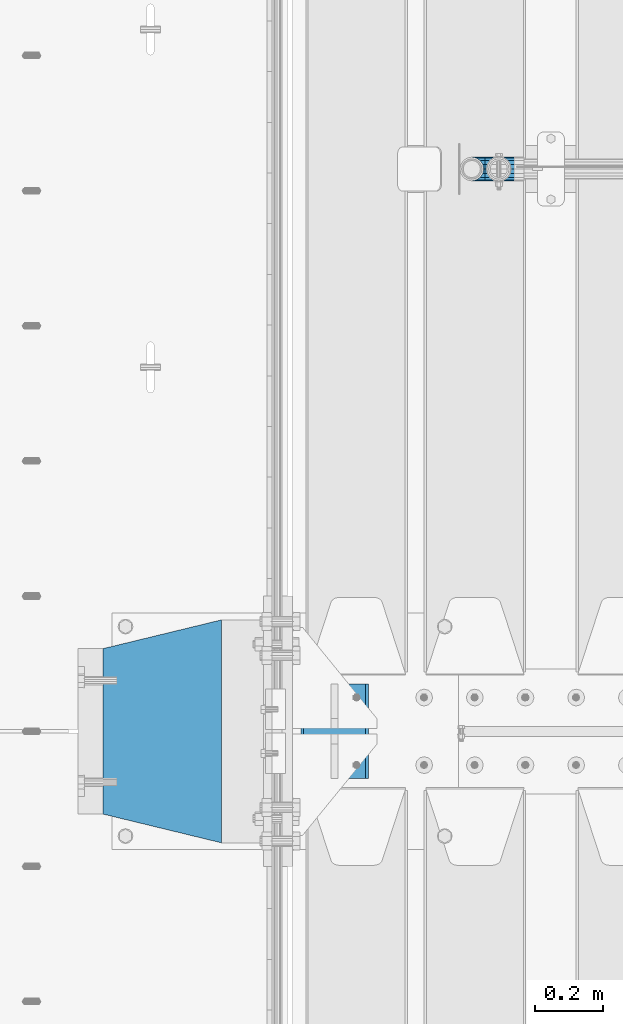
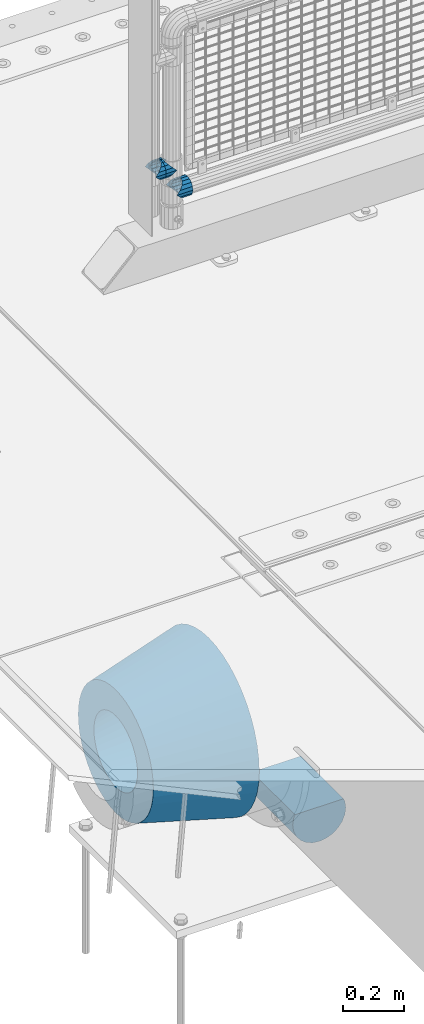
# One storey, part 144 of 240: 5 beams.
"""IFC2X3 building model written with IfcOpenShell, lengths in millimetres."""

from ifc_helpers import new_model, si_unit, frame, origin_with_axes, place, context, subcontext, project, spatial, faceted_brep, material, type_object, element, save


model = new_model("IFC2X3")

# Units and contexts
model_context = context("Model", 3, precision=1e-05, world=origin_with_axes())
body_context = subcontext(model_context, "Body", "Model", "MODEL_VIEW")
ifc_project = project(units=[si_unit("LENGTHUNIT", "METRE", prefix="MILLI"), si_unit("AREAUNIT", "SQUARE_METRE"), si_unit("VOLUMEUNIT", "CUBIC_METRE"), si_unit("MASSUNIT", "GRAM", prefix="KILO"), si_unit("TIMEUNIT", "SECOND"), si_unit("PLANEANGLEUNIT", "RADIAN"), si_unit("SOLIDANGLEUNIT", "STERADIAN"), si_unit("THERMODYNAMICTEMPERATUREUNIT", "DEGREE_CELSIUS"), si_unit("LUMINOUSINTENSITYUNIT", "LUMEN")], contexts=[model_context])

# Site, building, storey
site_placement = place(None, origin_with_axes())
site = spatial("IfcSite", under=ifc_project, at=site_placement, CompositionType="ELEMENT")
building_placement = place(site_placement, origin_with_axes())
building = spatial("IfcBuilding", under=site, at=building_placement, Name="Standard", CompositionType="ELEMENT")
storey_placement = place(building_placement, origin_with_axes())
storey = spatial("IfcBuildingStorey", under=building, at=storey_placement, Name="Undefined", CompositionType="ELEMENT", Elevation=0.0)

# Beams
ifc_material_1 = material(Name="STEEL/S355N")
beam_type_1 = type_object("IfcBeamType", Name="D200", PredefinedType="NOTDEFINED")
beam_1_placement = place(storey_placement, frame((42585.0, 32860.0, -928.0), z_axis=(0.0, 0.0, 1.0), x_axis=(0.0, 1.0, 0.0)))
element("IfcBeam", 1, at=beam_1_placement, inside=storey, type_object=beam_type_1, material=ifc_material_1, ObjectType="D200", context=body_context, shape_type="Brep", body=[
    faceted_brep([(0.0, 100.0, 0.0), (0.0, 96.5925826289094, 25.8819045102521), (280.0, 96.5925826289094, 25.8819045102521), (280.0, 100.0, 0.0), (0.0, 96.5925826289094, -25.8819045102521), (280.0, 96.5925826289094, -25.8819045102521), (0.0, 86.6025403784442, -50.0), (280.0, 86.6025403784442, -50.0), (0.0, 70.7106781186521, -70.7106781186548), (280.0, 70.7106781186521, -70.7106781186548), (0.0, 50.0, -86.6025403784438), (280.0, 50.0, -86.6025403784438), (0.0, 25.88190451025, -96.5925826289067), (280.0, 25.88190451025, -96.5925826289067), (0.0, 0.0, -100.0), (280.0, 0.0, -100.0), (0.0, -25.88190451025, -96.5925826289069), (280.0, -25.88190451025, -96.5925826289069), (0.0, -50.0, -86.6025403784439), (280.0, -50.0, -86.6025403784439), (0.0, -70.7106781186521, -70.7106781186548), (280.0, -70.7106781186521, -70.7106781186548), (0.0, -86.6025403784442, -50.0), (280.0, -86.6025403784442, -50.0), (0.0, -96.5925826289094, -25.8819045102522), (280.0, -96.5925826289094, -25.8819045102522), (0.0, -100.0, 0.0), (280.0, -100.0, 0.0), (0.0, -96.5925826289094, 25.8819045102521), (280.0, -96.5925826289094, 25.8819045102521), (280.0, -91.5731031269243, 38.0), (0.0, -91.5731031269243, 38.0), (0.0, 91.5731031269243, 38.0), (280.0, 91.5731031269243, 38.0)], [[[0, 1, 2, 3]], [[4, 0, 3, 5]], [[6, 4, 5, 7]], [[8, 6, 7, 9]], [[10, 8, 9, 11]], [[12, 10, 11, 13]], [[14, 12, 13, 15]], [[16, 14, 15, 17]], [[18, 16, 17, 19]], [[20, 18, 19, 21]], [[22, 20, 21, 23]], [[24, 22, 23, 25]], [[26, 24, 25, 27]], [[28, 26, 27, 29]], [[28, 29, 30, 31]], [[1, 0, 4, 6, 8, 10, 12, 14, 16, 18, 20, 22, 24, 26, 28, 31, 32]], [[2, 1, 32, 33]], [[29, 27, 25, 23, 21, 19, 17, 15, 13, 11, 9, 7, 5, 3, 2, 33, 30]], [[32, 31, 30, 33]]]),
])
ifc_material_2 = material(Name="Misc_Undefined")
beam_type_2 = type_object("IfcBeamType", PredefinedType="NOTDEFINED")
beam_2_placement = place(storey_placement, frame((43071.0, 34664.5, 298.67), z_axis=(0.0, 1.0, 0.0), x_axis=(1.0, 0.0, 0.0)))
element("IfcBeam", 2, at=beam_2_placement, inside=storey, type_object=beam_type_2, material=ifc_material_2, context=body_context, shape_type="Brep", body=[
    faceted_brep([(0.0, 0.0, 35.1500000000015), (13.4513226476338, 13.4513226476329, 32.4743655677739), (13.4513226476338, -13.4513226476329, 32.4743655677739), (24.8548033587067, -16.3810424079947, -24.8548033587067), (24.8548033587067, -24.8548033587072, -24.8548033587067), (32.4743655677739, -32.4743655677717, -13.4513226476338), (32.4743655677739, -26.8123795176712, -13.4513226476338), (27.1226768591223, -21.4606908090117, -21.4606908090136), (0.0, 0.0, -35.1500000000015), (13.4513226476338, -13.4513226476329, -32.4743655677739), (13.4513226476338, 13.4513226476329, -32.4743655677739), (20.0882031229994, -11.6144421722805, -28.0397438117143), (16.6306603983758, 0.0, -30.3499999999985), (20.0882031229994, 11.6144421722805, -28.0397438117143), (24.8548033587067, 16.3810424080013, -24.8548033587067), (24.8548033587067, 24.8548033587072, -24.8548033587067), (27.1226768591223, 21.4606908090117, -21.4606908090136), (32.4743655677739, 26.8123795176712, -13.4513226476338), (32.4743655677739, 32.4743655677717, -13.4513226476338), (32.8397438117172, 28.0397438117175, -11.6144421722784), (35.1500000000015, 30.35, 0.0), (35.1500000000015, 35.15, 0.0), (32.8397438117099, 28.0397438117175, 11.6144421722784), (32.4743655677739, 26.8123795176755, 13.4513226476338), (32.4743655677739, 32.4743655677717, 13.4513226476338), (27.1226768591005, 21.4606908090117, 21.4606908090136), (24.8548033587067, 16.3810424080013, 24.8548033587067), (24.8548033587067, 24.8548033587072, 24.8548033587067), (20.0882031229849, 11.6144421722805, 28.0397438117143), (16.6306603983685, 0.0, 30.3499999999985), (20.0882031229849, -11.6144421722805, 28.0397438117143), (24.8548033587067, -16.3810424080078, 24.8548033587067), (24.8548033587067, -24.8548033587072, 24.8548033587067), (27.1226768591005, -21.4606908090117, 21.4606908090136), (32.4743655677739, -26.8123795176712, 13.4513226476338), (32.4743655677739, -32.4743655677717, 13.4513226476338), (32.8397438117099, -28.0397438117175, 11.6144421722784), (35.1500000000015, -30.35, 0.0), (35.1500000000015, -35.15, 0.0), (32.8397438117172, -28.0397438117175, -11.6144421722784), (60.1500000000015, -24.8548033587072, -24.8548033587067), (60.1500000000015, -32.4743655677717, -13.4513226476338), (60.1500000000015, -13.4513226476329, -32.4743655677739), (60.1500000000015, 0.0, -35.1500000000015), (60.1500000000015, 13.4513226476329, -32.4743655677739), (60.1500000000015, 24.8548033587072, -24.8548033587067), (60.1500000000015, 32.4743655677717, -13.4513226476338), (60.1500000000015, 35.15, 0.0), (60.1500000000015, 32.4743655677717, 13.4513226476338), (60.1500000000015, 24.8548033587072, 24.8548033587067), (60.1500000000015, 13.4513226476329, 32.4743655677739), (60.1500000000015, 0.0, 35.1500000000015), (60.1500000000015, -13.4513226476329, 32.4743655677739), (60.1500000000015, -24.8548033587072, 24.8548033587067), (60.1500000000015, -32.4743655677717, 13.4513226476338), (60.1500000000015, -35.15, 0.0), (60.1500000000015, -21.4606908090117, 21.4606908090136), (60.1500000000015, -11.6144421722805, 28.0397438117143), (60.1500000000015, 0.0, 30.3499999999985), (60.1500000000015, 11.6144421722805, 28.0397438117143), (60.1500000000015, 21.4606908090117, 21.4606908090136), (60.1500000000015, 28.0397438117175, 11.6144421722784), (60.1500000000015, 30.35, 0.0), (60.1500000000015, 28.0397438117175, -11.6144421722784), (60.1500000000015, 21.4606908090117, -21.4606908090136), (60.1500000000015, 11.6144421722805, -28.0397438117143), (60.1500000000015, 0.0, -30.3499999999985), (60.1500000000015, -11.6144421722805, -28.0397438117143), (60.1500000000015, -21.4606908090117, -21.4606908090136), (60.1500000000015, -28.0397438117175, -11.6144421722784), (60.1500000000015, -30.35, 0.0), (60.1500000000015, -28.0397438117175, 11.6144421722784)], [[[0, 1, 2]], [[3, 4, 5, 6, 7]], [[8, 9, 10]], [[10, 9, 4, 3, 11, 12, 13, 14, 15]], [[15, 14, 16, 17, 18]], [[18, 17, 19, 20, 21]], [[21, 20, 22, 23, 24]], [[24, 23, 25, 26, 27]], [[27, 26, 28, 29, 30, 31, 32, 2, 1]], [[33, 34, 35, 32, 31]], [[36, 37, 38, 35, 34]], [[6, 5, 38, 37, 39]], [[40, 41, 5, 4]], [[42, 40, 4, 9]], [[43, 42, 9, 8]], [[44, 43, 8, 10]], [[45, 44, 10, 15]], [[46, 45, 15, 18]], [[47, 46, 18, 21]], [[48, 47, 21, 24]], [[49, 48, 24, 27]], [[50, 49, 27, 1]], [[51, 50, 1, 0]], [[52, 51, 0, 2]], [[53, 52, 2, 32]], [[54, 53, 32, 35]], [[55, 54, 35, 38]], [[41, 55, 38, 5]], [[40, 42, 43, 44, 45, 46, 47, 48, 49, 50, 51, 52, 53, 54, 55, 41], [56, 57, 58, 59, 60, 61, 62, 63, 64, 65, 66, 67, 68, 69, 70, 71]], [[71, 70, 37, 36]], [[56, 71, 36, 34, 33]], [[57, 56, 33, 31, 30]], [[58, 57, 30, 29]], [[59, 58, 29, 28]], [[25, 60, 59, 28, 26]], [[22, 61, 60, 25, 23]], [[62, 61, 22, 20]], [[63, 62, 20, 19]], [[64, 63, 19, 17, 16]], [[65, 64, 16, 14, 13]], [[66, 65, 13, 12]], [[67, 66, 12, 11]], [[7, 68, 67, 11, 3]], [[39, 69, 68, 7, 6]], [[70, 69, 39, 37]]]),
])
beam_3_placement = place(storey_placement, frame((42991.0, 34664.5, 398.670000000001), z_axis=(0.0, -1.0, 0.0), x_axis=(1.0, 0.0, 0.0)))
element("IfcBeam", 3, at=beam_3_placement, inside=storey, type_object=beam_type_2, material=ifc_material_2, context=body_context, shape_type="Brep", body=[
    faceted_brep([(0.0, 0.0, -35.1500000000015), (13.4513226476338, -13.4513226476329, -32.4743655677739), (13.4513226476338, 13.4513226476329, -32.4743655677739), (32.4743655677739, 32.4743655677717, 13.4513226476338), (32.4743655677739, 26.8123795176755, 13.4513226476338), (27.1226768591005, 21.4606908090117, 21.4606908090136), (24.8548033587067, 16.3810424080013, 24.8548033587067), (24.8548033587067, 24.8548033587072, 24.8548033587067), (0.0, 0.0, 35.1500000000015), (13.4513226476338, 13.4513226476329, 32.4743655677739), (13.4513226476338, -13.4513226476329, 32.4743655677739), (20.0882031229849, 11.6144421722805, 28.0397438117143), (16.6306603983685, 0.0, 30.3499999999985), (20.0882031229849, -11.6144421722805, 28.0397438117143), (24.8548033587067, -16.3810424080078, 24.8548033587067), (24.8548033587067, -24.8548033587072, 24.8548033587067), (27.1226768591005, -21.4606908090117, 21.4606908090136), (32.4743655677739, -26.8123795176712, 13.4513226476338), (32.4743655677739, -32.4743655677717, 13.4513226476338), (32.8397438117099, -28.0397438117175, 11.6144421722784), (35.1500000000015, -30.35, 0.0), (35.1500000000015, -35.15, 0.0), (32.4743655677739, -26.8123795176712, -13.4513226476338), (32.4743655677739, -32.4743655677717, -13.4513226476338), (32.8397438117172, -28.0397438117175, -11.6144421722784), (24.8548033587067, -16.3810424079947, -24.8548033587067), (24.8548033587067, -24.8548033587072, -24.8548033587067), (27.1226768591223, -21.4606908090117, -21.4606908090136), (20.0882031229994, -11.6144421722805, -28.0397438117143), (16.6306603983758, 0.0, -30.3499999999985), (20.0882031229994, 11.6144421722805, -28.0397438117143), (24.8548033587067, 16.3810424080013, -24.8548033587067), (24.8548033587067, 24.8548033587072, -24.8548033587067), (27.1226768591223, 21.4606908090117, -21.4606908090136), (32.4743655677739, 26.8123795176712, -13.4513226476338), (32.4743655677739, 32.4743655677717, -13.4513226476338), (32.8397438117172, 28.0397438117175, -11.6144421722784), (35.1500000000015, 30.35, 0.0), (35.1500000000015, 35.15, 0.0), (32.8397438117099, 28.0397438117175, 11.6144421722784), (40.1500000000015, -35.15, 0.0), (40.1500000000015, -32.4743655677717, 13.4513226476338), (40.1500000000015, -24.8548033587072, 24.8548033587067), (40.1500000000015, -13.4513226476329, 32.4743655677739), (40.1500000000015, 0.0, 35.1500000000015), (40.1500000000015, 13.4513226476329, 32.4743655677739), (40.1500000000015, 24.8548033587072, 24.8548033587067), (40.1500000000015, 32.4743655677717, 13.4513226476338), (40.1500000000015, 35.15, 0.0), (40.1500000000015, -24.8548033587072, -24.8548033587067), (40.1500000000015, -32.4743655677717, -13.4513226476338), (40.1500000000015, -13.4513226476329, -32.4743655677739), (40.1500000000015, 0.0, -35.1500000000015), (40.1500000000015, 13.4513226476329, -32.4743655677739), (40.1500000000015, 24.8548033587072, -24.8548033587067), (40.1500000000015, 32.4743655677717, -13.4513226476338), (40.1500000000015, -21.4606908090117, 21.4606908090136), (40.1500000000015, -11.6144421722805, 28.0397438117143), (40.1500000000015, 0.0, 30.3499999999985), (40.1500000000015, 11.6144421722805, 28.0397438117143), (40.1500000000015, 21.4606908090117, 21.4606908090136), (40.1500000000015, 28.0397438117175, 11.6144421722784), (40.1500000000015, 30.35, 0.0), (40.1500000000015, 28.0397438117175, -11.6144421722784), (40.1500000000015, 21.4606908090117, -21.4606908090136), (40.1500000000015, 11.6144421722805, -28.0397438117143), (40.1500000000015, 0.0, -30.3499999999985), (40.1500000000015, -11.6144421722805, -28.0397438117143), (40.1500000000015, -21.4606908090117, -21.4606908090136), (40.1500000000015, -28.0397438117175, -11.6144421722784), (40.1500000000015, -30.35, 0.0), (40.1500000000015, -28.0397438117175, 11.6144421722784)], [[[0, 1, 2]], [[3, 4, 5, 6, 7]], [[8, 9, 10]], [[7, 6, 11, 12, 13, 14, 15, 10, 9]], [[16, 17, 18, 15, 14]], [[19, 20, 21, 18, 17]], [[22, 23, 21, 20, 24]], [[25, 26, 23, 22, 27]], [[2, 1, 26, 25, 28, 29, 30, 31, 32]], [[32, 31, 33, 34, 35]], [[35, 34, 36, 37, 38]], [[38, 37, 39, 4, 3]], [[40, 41, 18, 21]], [[41, 42, 15, 18]], [[42, 43, 10, 15]], [[43, 44, 8, 10]], [[44, 45, 9, 8]], [[45, 46, 7, 9]], [[46, 47, 3, 7]], [[47, 48, 38, 3]], [[49, 50, 23, 26]], [[51, 49, 26, 1]], [[52, 51, 1, 0]], [[53, 52, 0, 2]], [[54, 53, 2, 32]], [[55, 54, 32, 35]], [[48, 55, 35, 38]], [[50, 40, 21, 23]], [[49, 51, 52, 53, 54, 55, 48, 47, 46, 45, 44, 43, 42, 41, 40, 50], [56, 57, 58, 59, 60, 61, 62, 63, 64, 65, 66, 67, 68, 69, 70, 71]], [[63, 62, 37, 36]], [[33, 64, 63, 36, 34]], [[30, 65, 64, 33, 31]], [[66, 65, 30, 29]], [[67, 66, 29, 28]], [[68, 67, 28, 25, 27]], [[69, 68, 27, 22, 24]], [[70, 69, 24, 20]], [[71, 70, 20, 19]], [[16, 56, 71, 19, 17]], [[13, 57, 56, 16, 14]], [[58, 57, 13, 12]], [[59, 58, 12, 11]], [[60, 59, 11, 6, 5]], [[61, 60, 5, 4, 39]], [[62, 61, 39, 37]]]),
])
beam_4_placement = place(storey_placement, frame((43071.0, 34664.5, 398.670000000001), z_axis=(0.0, 1.0, 0.0), x_axis=(-1.0, 0.0, 0.0)))
element("IfcBeam", 4, at=beam_4_placement, inside=storey, type_object=beam_type_2, material=ifc_material_2, context=body_context, shape_type="Brep", body=[
    faceted_brep([(0.0, 0.0, -35.1500000000015), (13.4513226476338, -13.4513226476329, -32.4743655677739), (13.4513226476338, 13.4513226476329, -32.4743655677739), (27.1226768591005, -21.4606908090117, 21.4606908090136), (32.4743655677739, -26.8123795176712, 13.4513226476338), (32.4743655677739, -32.4743655677717, 13.4513226476338), (24.8548033587067, -24.8548033587072, 24.8548033587067), (24.8548033587067, -16.3810424080078, 24.8548033587067), (32.8397438117099, -28.0397438117175, 11.6144421722784), (35.1500000000015, -30.35, 0.0), (35.1500000000015, -35.15, 0.0), (32.4743655677739, -26.8123795176712, -13.4513226476338), (32.4743655677739, -32.4743655677717, -13.4513226476338), (32.8397438117172, -28.0397438117175, -11.6144421722784), (24.8548033587067, -16.3810424079947, -24.8548033587067), (24.8548033587067, -24.8548033587072, -24.8548033587067), (27.1226768591223, -21.4606908090117, -21.4606908090136), (20.0882031229994, -11.6144421722805, -28.0397438117143), (16.6306603983758, 0.0, -30.3499999999985), (20.0882031229994, 11.6144421722805, -28.0397438117143), (24.8548033587067, 16.3810424080013, -24.8548033587067), (24.8548033587067, 24.8548033587072, -24.8548033587067), (27.1226768591223, 21.4606908090117, -21.4606908090136), (32.4743655677739, 26.8123795176712, -13.4513226476338), (32.4743655677739, 32.4743655677717, -13.4513226476338), (32.8397438117172, 28.0397438117175, -11.6144421722784), (35.1500000000015, 30.35, 0.0), (35.1500000000015, 35.15, 0.0), (32.8397438117099, 28.0397438117175, 11.6144421722784), (32.4743655677739, 26.8123795176755, 13.4513226476338), (32.4743655677739, 32.4743655677717, 13.4513226476338), (27.1226768591005, 21.4606908090117, 21.4606908090136), (24.8548033587067, 16.3810424080013, 24.8548033587067), (24.8548033587067, 24.8548033587072, 24.8548033587067), (0.0, 0.0, 35.1500000000015), (13.4513226476338, 13.4513226476329, 32.4743655677739), (13.4513226476338, -13.4513226476329, 32.4743655677739), (20.0882031229849, 11.6144421722805, 28.0397438117143), (16.6306603983685, 0.0, 30.3499999999985), (20.0882031229849, -11.6144421722805, 28.0397438117143), (40.1500000000015, -35.15, 0.0), (40.1500000000015, -32.4743655677717, 13.4513226476338), (40.1500000000015, -24.8548033587072, 24.8548033587067), (40.1500000000015, -13.4513226476329, 32.4743655677739), (40.1500000000015, 0.0, 35.1500000000015), (40.1500000000015, -24.8548033587072, -24.8548033587067), (40.1500000000015, -32.4743655677717, -13.4513226476338), (40.1500000000015, -13.4513226476329, -32.4743655677739), (40.1500000000015, 0.0, -35.1500000000015), (40.1500000000015, 13.4513226476329, -32.4743655677739), (40.1500000000015, 24.8548033587072, -24.8548033587067), (40.1500000000015, 32.4743655677717, -13.4513226476338), (40.1500000000015, 35.15, 0.0), (40.1500000000015, 32.4743655677717, 13.4513226476338), (40.1500000000015, 24.8548033587072, 24.8548033587067), (40.1500000000015, 13.4513226476329, 32.4743655677739), (40.1500000000015, -21.4606908090117, 21.4606908090136), (40.1500000000015, -11.6144421722805, 28.0397438117143), (40.1500000000015, 0.0, 30.3499999999985), (40.1500000000015, 11.6144421722805, 28.0397438117143), (40.1500000000015, 21.4606908090117, 21.4606908090136), (40.1500000000015, 28.0397438117175, 11.6144421722784), (40.1500000000015, 30.35, 0.0), (40.1500000000015, 28.0397438117175, -11.6144421722784), (40.1500000000015, 21.4606908090117, -21.4606908090136), (40.1500000000015, 11.6144421722805, -28.0397438117143), (40.1500000000015, 0.0, -30.3499999999985), (40.1500000000015, -11.6144421722805, -28.0397438117143), (40.1500000000015, -21.4606908090117, -21.4606908090136), (40.1500000000015, -28.0397438117175, -11.6144421722784), (40.1500000000015, -30.35, 0.0), (40.1500000000015, -28.0397438117175, 11.6144421722784)], [[[0, 1, 2]], [[3, 4, 5, 6, 7]], [[8, 9, 10, 5, 4]], [[11, 12, 10, 9, 13]], [[14, 15, 12, 11, 16]], [[2, 1, 15, 14, 17, 18, 19, 20, 21]], [[21, 20, 22, 23, 24]], [[24, 23, 25, 26, 27]], [[27, 26, 28, 29, 30]], [[30, 29, 31, 32, 33]], [[34, 35, 36]], [[33, 32, 37, 38, 39, 7, 6, 36, 35]], [[40, 41, 5, 10]], [[41, 42, 6, 5]], [[42, 43, 36, 6]], [[43, 44, 34, 36]], [[45, 46, 12, 15]], [[47, 45, 15, 1]], [[48, 47, 1, 0]], [[49, 48, 0, 2]], [[50, 49, 2, 21]], [[51, 50, 21, 24]], [[52, 51, 24, 27]], [[53, 52, 27, 30]], [[54, 53, 30, 33]], [[55, 54, 33, 35]], [[44, 55, 35, 34]], [[46, 40, 10, 12]], [[45, 47, 48, 49, 50, 51, 52, 53, 54, 55, 44, 43, 42, 41, 40, 46], [56, 57, 58, 59, 60, 61, 62, 63, 64, 65, 66, 67, 68, 69, 70, 71]], [[59, 58, 38, 37]], [[60, 59, 37, 32, 31]], [[61, 60, 31, 29, 28]], [[62, 61, 28, 26]], [[63, 62, 26, 25]], [[22, 64, 63, 25, 23]], [[19, 65, 64, 22, 20]], [[66, 65, 19, 18]], [[67, 66, 18, 17]], [[68, 67, 17, 14, 16]], [[69, 68, 16, 11, 13]], [[70, 69, 13, 9]], [[71, 70, 9, 8]], [[3, 56, 71, 8, 4]], [[39, 57, 56, 3, 7]], [[58, 57, 39, 38]]]),
])
ifc_material_3 = material(Name="SCN-500-E2")
beam_type_3 = type_object("IfcBeamType", PredefinedType="NOTDEFINED")
beam_5_placement = place(storey_placement, frame((42250.0, 33000.0, -515.0), z_axis=(0.0, 0.0, 1.0), x_axis=(-1.0, 0.0, 0.0)))
element("IfcBeam", 5, at=beam_5_placement, inside=storey, type_object=beam_type_3, material=ifc_material_3, context=body_context, shape_type="Brep", body=[
    faceted_brep([(0.0, -330.0, 0.0), (0.0, -326.641075820706, -46.9638966301842), (350.0, -242.506253260828, -34.8671353769549), (350.0, -245.0, 0.0), (0.0, -316.632681292787, -92.9717437576718), (350.0, -235.075778535553, -69.0244764261503), (0.0, -300.178558466992, -137.086954290623), (350.0, -222.859838861856, -101.776678185462), (0.0, -277.613665834288, -178.411469760347), (350.0, -206.107115543637, -132.457000276621), (0.0, -249.397359536903, -216.104042201944), (350.0, -185.158645716794, -160.440879816595), (0.0, -216.104042201943, -249.397359536905), (350.0, -160.440879816597, -185.158645716793), (0.0, -178.411469760344, -277.61366583429), (350.0, -132.45700027662, -206.107115543639), (0.0, -137.086954290622, -300.178558466991), (350.0, -101.776678185459, -222.859838861857), (0.0, -92.9717437576692, -316.632681292784), (350.0, -69.0244764261515, -235.075778535552), (0.0, -46.9638966301864, -326.641075820708), (350.0, -34.8671353769532, -242.506253260829), (0.0, 0.0, -330.0), (350.0, 0.0, -245.0), (0.0, 46.9638966301864, -326.641075820708), (350.0, 34.8671353769532, -242.506253260829), (0.0, 92.9717437576692, -316.632681292784), (350.0, 69.0244764261515, -235.075778535552), (0.0, 137.086954290622, -300.178558466991), (350.0, 101.776678185459, -222.859838861857), (0.0, 178.411469760344, -277.61366583429), (350.0, 132.45700027662, -206.107115543639), (0.0, 216.104042201943, -249.397359536905), (350.0, 160.440879816597, -185.158645716793), (0.0, 249.397359536903, -216.104042201944), (350.0, 185.158645716794, -160.440879816595), (0.0, 277.613665834288, -178.411469760347), (350.0, 206.107115543637, -132.457000276621), (0.0, 300.178558466992, -137.086954290623), (350.0, 222.859838861856, -101.776678185462), (0.0, 316.632681292787, -92.9717437576717), (350.0, 235.075778535553, -69.0244764261502), (0.0, 326.641075820706, -46.9638966301841), (350.0, 242.506253260828, -34.8671353769548), (0.0, 330.0, 0.0), (350.0, 245.0, 0.0), (0.0, 326.641075820706, 46.9638966301841), (350.0, 242.506253260828, 34.8671353769549), (0.0, 316.632681292787, 92.9717437576718), (350.0, 235.075778535553, 69.0244764261503), (0.0, 300.178558466992, 137.086954290622), (350.0, 222.859838861856, 101.776678185462), (0.0, 277.613665834288, 178.411469760347), (350.0, 206.107115543637, 132.457000276621), (0.0, 249.397359536903, 216.104042201944), (350.0, 185.158645716794, 160.440879816595), (0.0, 216.104042201943, 249.397359536905), (350.0, 160.440879816597, 185.158645716793), (0.0, 178.411469760344, 277.61366583429), (350.0, 132.45700027662, 206.107115543639), (0.0, 137.086954290622, 300.178558466991), (350.0, 101.776678185459, 222.859838861857), (0.0, 92.9717437576692, 316.632681292784), (350.0, 69.0244764261515, 235.075778535552), (0.0, 46.9638966301864, 326.641075820708), (350.0, 34.8671353769532, 242.506253260829), (0.0, 0.0, 330.0), (350.0, 0.0, 245.0), (0.0, -46.9638966301864, 326.641075820708), (350.0, -34.8671353769532, 242.506253260829), (0.0, -92.9717437576692, 316.632681292784), (350.0, -69.0244764261515, 235.075778535552), (0.0, -137.086954290622, 300.178558466991), (350.0, -101.776678185459, 222.859838861857), (0.0, -178.411469760344, 277.61366583429), (350.0, -132.45700027662, 206.107115543639), (0.0, -216.104042201943, 249.397359536905), (350.0, -160.440879816597, 185.158645716793), (0.0, -249.397359536903, 216.104042201944), (350.0, -185.158645716794, 160.440879816595), (0.0, -277.613665834288, 178.411469760347), (350.0, -206.107115543637, 132.457000276621), (0.0, -300.178558466992, 137.086954290623), (350.0, -222.859838861856, 101.776678185462), (0.0, -316.632681292787, 92.9717437576718), (350.0, -235.075778535553, 69.0244764261503), (0.0, -326.641075820706, 46.9638966301841), (350.0, -242.506253260828, 34.8671353769549), (0.0, -227.093265923133, 0.0), (0.0, -224.781783917482, 32.3187414128026), (350.0, -140.646961357605, 20.2219801595734), (350.0, -142.093265923133, 0.0), (0.0, -217.894393008413, 63.9795664499945), (350.0, -136.337490251179, 40.032299118473), (0.0, -206.571300613236, 94.3379520160985), (350.0, -129.252581008099, 59.0276759109381), (0.0, -191.043012240007, 122.775888927343), (350.0, -119.536461949356, 76.8214194436173), (0.0, -171.625639060127, 148.714462796454), (350.0, -107.386925240011, 93.0513004111044), (0.0, -148.714462796452, 171.625639060125), (350.0, -93.0513004111053, 107.386925240013), (0.0, -122.775888927346, 191.043012240005), (350.0, -76.821419443615, 119.536461949355), (0.0, -94.3379520160961, 206.571300613232), (350.0, -59.0276759109402, 129.252581008098), (0.0, -63.9795664499979, 217.894393008413), (350.0, -40.032299118473, 136.337490251181), (0.0, -32.3187414128042, 224.781783917484), (350.0, -20.2219801595711, 140.646961357605), (0.0, 0.0, 227.093265923131), (350.0, 0.0, 142.093265923131), (0.0, 32.3187414128042, 224.781783917484), (350.0, 20.2219801595711, 140.646961357605), (0.0, 63.9795664499979, 217.894393008413), (350.0, 40.032299118473, 136.337490251181), (0.0, 94.3379520160961, 206.571300613232), (350.0, 59.0276759109402, 129.252581008098), (0.0, 122.775888927346, 191.043012240005), (350.0, 76.821419443615, 119.536461949355), (0.0, 148.714462796452, 171.625639060125), (350.0, 93.0513004111053, 107.386925240013), (0.0, 171.625639060127, 148.714462796454), (350.0, 107.386925240011, 93.0513004111044), (0.0, 191.043012240007, 122.775888927343), (350.0, 119.536461949356, 76.8214194436174), (0.0, 206.571300613236, 94.3379520160985), (350.0, 129.252581008099, 59.0276759109382), (0.0, 217.894393008413, 63.9795664499945), (350.0, 136.337490251179, 40.032299118473), (0.0, 224.781783917482, 32.3187414128025), (350.0, 140.646961357605, 20.2219801595733), (0.0, 227.093265923133, 0.0), (350.0, 142.093265923133, 0.0), (0.0, 224.781783917482, -32.3187414128026), (350.0, 140.646961357605, -20.2219801595734), (0.0, 217.894393008413, -63.9795664499945), (350.0, 136.337490251179, -40.032299118473), (0.0, 206.571300613236, -94.3379520160985), (350.0, 129.252581008099, -59.0276759109381), (0.0, 191.043012240007, -122.775888927343), (350.0, 119.536461949356, -76.8214194436174), (0.0, 171.625639060127, -148.714462796454), (350.0, 107.386925240011, -93.0513004111044), (0.0, 148.714462796452, -171.625639060125), (350.0, 93.0513004111053, -107.386925240013), (0.0, 122.775888927346, -191.043012240005), (350.0, 76.821419443615, -119.536461949355), (0.0, 94.3379520160961, -206.571300613232), (350.0, 59.0276759109402, -129.252581008098), (0.0, 63.9795664499979, -217.894393008413), (350.0, 40.032299118473, -136.337490251181), (0.0, 32.3187414128042, -224.781783917484), (350.0, 20.2219801595711, -140.646961357605), (0.0, 0.0, -227.093265923131), (350.0, 0.0, -142.093265923131), (0.0, -32.3187414128042, -224.781783917484), (350.0, -20.2219801595711, -140.646961357605), (0.0, -63.9795664499979, -217.894393008413), (350.0, -40.032299118473, -136.337490251181), (0.0, -94.3379520160961, -206.571300613232), (350.0, -59.0276759109402, -129.252581008098), (0.0, -122.775888927346, -191.043012240005), (350.0, -76.821419443615, -119.536461949355), (0.0, -148.714462796452, -171.625639060125), (350.0, -93.0513004111053, -107.386925240013), (0.0, -171.625639060127, -148.714462796454), (350.0, -107.386925240011, -93.0513004111044), (0.0, -191.043012240007, -122.775888927343), (350.0, -119.536461949356, -76.8214194436174), (0.0, -206.571300613236, -94.3379520160985), (350.0, -129.252581008099, -59.0276759109381), (0.0, -217.894393008413, -63.9795664499945), (350.0, -136.337490251179, -40.032299118473), (0.0, -224.781783917482, -32.3187414128026), (350.0, -140.646961357605, -20.2219801595734)], [[[0, 1, 2, 3]], [[1, 4, 5, 2]], [[4, 6, 7, 5]], [[6, 8, 9, 7]], [[8, 10, 11, 9]], [[10, 12, 13, 11]], [[12, 14, 15, 13]], [[14, 16, 17, 15]], [[16, 18, 19, 17]], [[18, 20, 21, 19]], [[20, 22, 23, 21]], [[22, 24, 25, 23]], [[24, 26, 27, 25]], [[26, 28, 29, 27]], [[28, 30, 31, 29]], [[30, 32, 33, 31]], [[32, 34, 35, 33]], [[34, 36, 37, 35]], [[36, 38, 39, 37]], [[38, 40, 41, 39]], [[40, 42, 43, 41]], [[42, 44, 45, 43]], [[44, 46, 47, 45]], [[46, 48, 49, 47]], [[48, 50, 51, 49]], [[50, 52, 53, 51]], [[52, 54, 55, 53]], [[54, 56, 57, 55]], [[56, 58, 59, 57]], [[58, 60, 61, 59]], [[60, 62, 63, 61]], [[62, 64, 65, 63]], [[64, 66, 67, 65]], [[66, 68, 69, 67]], [[68, 70, 71, 69]], [[70, 72, 73, 71]], [[72, 74, 75, 73]], [[74, 76, 77, 75]], [[76, 78, 79, 77]], [[78, 80, 81, 79]], [[80, 82, 83, 81]], [[82, 84, 85, 83]], [[84, 86, 87, 85]], [[86, 0, 3, 87]], [[88, 89, 90, 91]], [[89, 92, 93, 90]], [[92, 94, 95, 93]], [[94, 96, 97, 95]], [[96, 98, 99, 97]], [[98, 100, 101, 99]], [[100, 102, 103, 101]], [[102, 104, 105, 103]], [[104, 106, 107, 105]], [[106, 108, 109, 107]], [[108, 110, 111, 109]], [[110, 112, 113, 111]], [[112, 114, 115, 113]], [[114, 116, 117, 115]], [[116, 118, 119, 117]], [[118, 120, 121, 119]], [[120, 122, 123, 121]], [[122, 124, 125, 123]], [[124, 126, 127, 125]], [[126, 128, 129, 127]], [[128, 130, 131, 129]], [[130, 132, 133, 131]], [[132, 134, 135, 133]], [[134, 136, 137, 135]], [[136, 138, 139, 137]], [[138, 140, 141, 139]], [[140, 142, 143, 141]], [[142, 144, 145, 143]], [[144, 146, 147, 145]], [[146, 148, 149, 147]], [[148, 150, 151, 149]], [[150, 152, 153, 151]], [[152, 154, 155, 153]], [[154, 156, 157, 155]], [[156, 158, 159, 157]], [[158, 160, 161, 159]], [[160, 162, 163, 161]], [[162, 164, 165, 163]], [[164, 166, 167, 165]], [[166, 168, 169, 167]], [[168, 170, 171, 169]], [[170, 172, 173, 171]], [[172, 174, 175, 173]], [[174, 88, 91, 175]], [[5, 7, 9, 11, 13, 15, 17, 19, 21, 23, 25, 27, 29, 31, 33, 35, 37, 39, 41, 43, 45, 47, 49, 51, 53, 55, 57, 59, 61, 63, 65, 67, 69, 71, 73, 75, 77, 79, 81, 83, 85, 87, 3, 2], [93, 95, 97, 99, 101, 103, 105, 107, 109, 111, 113, 115, 117, 119, 121, 123, 125, 127, 129, 131, 133, 135, 137, 139, 141, 143, 145, 147, 149, 151, 153, 155, 157, 159, 161, 163, 165, 167, 169, 171, 173, 175, 91, 90]], [[86, 84, 82, 80, 78, 76, 74, 72, 70, 68, 66, 64, 62, 60, 58, 56, 54, 52, 50, 48, 46, 44, 42, 40, 38, 36, 34, 32, 30, 28, 26, 24, 22, 20, 18, 16, 14, 12, 10, 8, 6, 4, 1, 0], [174, 172, 170, 168, 166, 164, 162, 160, 158, 156, 154, 152, 150, 148, 146, 144, 142, 140, 138, 136, 134, 132, 130, 128, 126, 124, 122, 120, 118, 116, 114, 112, 110, 108, 106, 104, 102, 100, 98, 96, 94, 92, 89, 88]]]),
])

save(model, "model.ifc")
